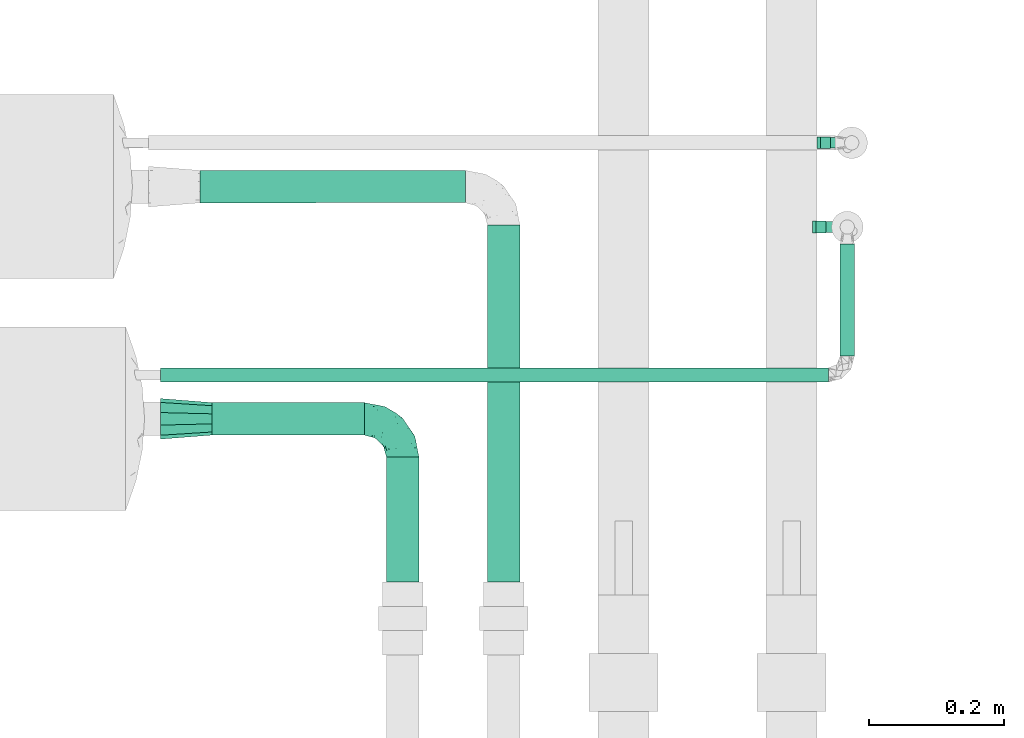
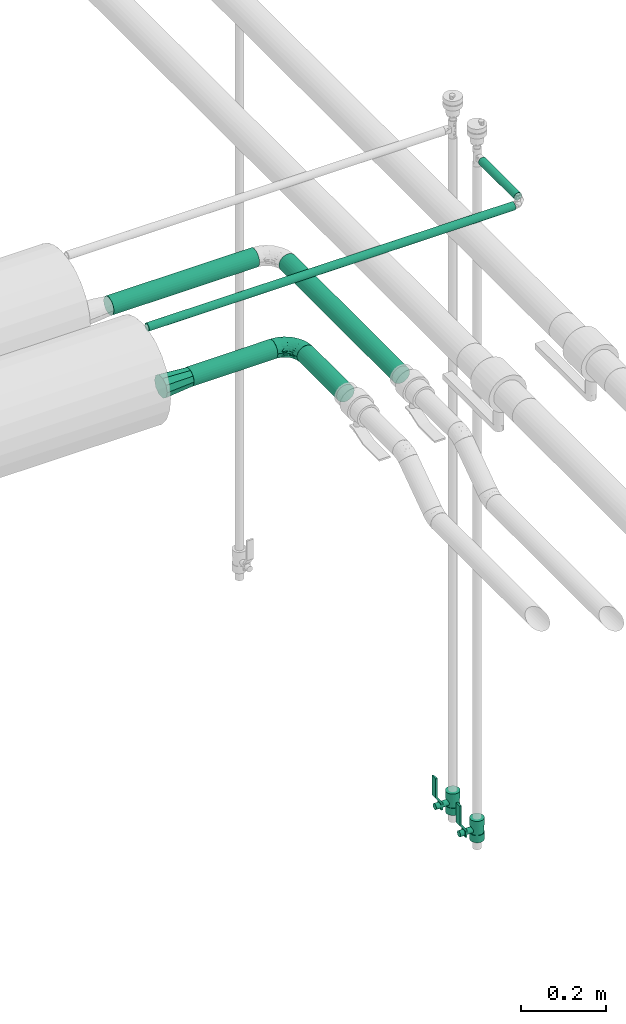
# One storey, part 588 of 827: 6 flow segments, 2 flow controllers, 2 flow fittings.
"""IFC2X3 building model written with IfcOpenShell, lengths in millimetres."""

from ifc_helpers import new_model, entity, si_unit, converted_unit, derived_unit, direction, frame, origin, origin_2d_with_axis, place, context, subcontext, project, spatial, polyline, circle, outline, extrude, faceted_brep, source, transform, mapped, material, material_list, type_object, type_shapes, element, save


model = new_model("IFC2X3")

# Units and contexts
model_context = context("Model", 3, precision=0.01, world=origin(), true_north=direction((6.12303176911189e-17, 1.0)))
body_context = subcontext(model_context, "Body", "Model", "MODEL_VIEW")
ifc_project = project(units=[si_unit("LENGTHUNIT", "METRE", prefix="MILLI"), si_unit("AREAUNIT", "SQUARE_METRE"), si_unit("VOLUMEUNIT", "CUBIC_METRE"), converted_unit("PLANEANGLEUNIT", "DEGREE", entity("IfcRatioMeasure", 0.0174532925199433), si_unit("PLANEANGLEUNIT", "RADIAN"), dimensions=[0, 0, 0, 0, 0, 0, 0]), si_unit("MASSUNIT", "GRAM", prefix="KILO"), derived_unit("MASSDENSITYUNIT", [(si_unit("MASSUNIT", "GRAM", prefix="KILO"), 1), (si_unit("LENGTHUNIT", "METRE"), -3)]), derived_unit("MOMENTOFINERTIAUNIT", [(si_unit("LENGTHUNIT", "METRE"), 4)]), si_unit("TIMEUNIT", "SECOND"), si_unit("FREQUENCYUNIT", "HERTZ"), si_unit("THERMODYNAMICTEMPERATUREUNIT", "DEGREE_CELSIUS"), derived_unit("THERMALTRANSMITTANCEUNIT", [(si_unit("MASSUNIT", "GRAM", prefix="KILO"), 1), (si_unit("THERMODYNAMICTEMPERATUREUNIT", "KELVIN"), -1), (si_unit("TIMEUNIT", "SECOND"), -3)]), derived_unit("VOLUMETRICFLOWRATEUNIT", [(si_unit("LENGTHUNIT", "METRE"), 3), (si_unit("TIMEUNIT", "SECOND"), -1)]), derived_unit("MASSFLOWRATEUNIT", [(si_unit("MASSUNIT", "GRAM", prefix="KILO"), 1), (si_unit("TIMEUNIT", "SECOND"), -1)]), derived_unit("ROTATIONALFREQUENCYUNIT", [(si_unit("TIMEUNIT", "SECOND"), -1)]), si_unit("ELECTRICCURRENTUNIT", "AMPERE"), si_unit("ELECTRICVOLTAGEUNIT", "VOLT"), si_unit("POWERUNIT", "WATT"), si_unit("FORCEUNIT", "NEWTON", prefix="KILO"), si_unit("ILLUMINANCEUNIT", "LUX"), si_unit("LUMINOUSFLUXUNIT", "LUMEN"), si_unit("LUMINOUSINTENSITYUNIT", "CANDELA"), derived_unit("USERDEFINED", [(si_unit("MASSUNIT", "GRAM", prefix="KILO"), -1), (si_unit("LENGTHUNIT", "METRE"), -2), (si_unit("TIMEUNIT", "SECOND"), 3), (si_unit("LUMINOUSFLUXUNIT", "LUMEN"), 1)]), derived_unit("LINEARVELOCITYUNIT", [(si_unit("LENGTHUNIT", "METRE"), 1), (si_unit("TIMEUNIT", "SECOND"), -1)]), si_unit("PRESSUREUNIT", "PASCAL"), derived_unit("USERDEFINED", [(si_unit("LENGTHUNIT", "METRE"), -2), (si_unit("MASSUNIT", "GRAM", prefix="KILO"), 1), (si_unit("TIMEUNIT", "SECOND"), -2)]), derived_unit("LINEARFORCEUNIT", [(si_unit("MASSUNIT", "GRAM", prefix="KILO"), 1), (si_unit("LENGTHUNIT", "METRE"), 1), (si_unit("TIMEUNIT", "SECOND"), -2), (si_unit("LENGTHUNIT", "METRE"), -1)]), derived_unit("PLANARFORCEUNIT", [(si_unit("MASSUNIT", "GRAM", prefix="KILO"), 1), (si_unit("LENGTHUNIT", "METRE"), 1), (si_unit("TIMEUNIT", "SECOND"), -2), (si_unit("LENGTHUNIT", "METRE"), -2)])], contexts=[model_context])

# Site, building, storey
site_placement = place(None, origin())
site = spatial("IfcSite", under=ifc_project, at=site_placement, CompositionType="ELEMENT")
building_placement = place(site_placement, origin())
building = spatial("IfcBuilding", under=site, at=building_placement, CompositionType="ELEMENT")
storey_placement = place(building_placement, frame((0.0, 0.0, 28200.0)))
storey = spatial("IfcBuildingStorey", under=building, at=storey_placement, Name="08", CompositionType="ELEMENT", Elevation=28200.0)

# Flow segments
pipe_segment_type = type_object("IfcPipeSegmentType", PredefinedType="NOTDEFINED")
flow_segment_1_placement = place(storey_placement, frame((25256.69, 14558.36, 3116.0)))
element("IfcFlowSegment", 1, at=flow_segment_1_placement, inside=storey, type_object=pipe_segment_type, context=body_context, shape_type="SweptSolid", body=[
    extrude(circle(Radius=10.65, at=origin_2d_with_axis()), frame((0.0, 12.25, 12.25), z_axis=(1.0, 0.0, 0.0), x_axis=(0.0, 1.0, 0.0)), (0.0, 0.0, 1.0), 991.985477356617),
])
flow_segment_2_placement = place(storey_placement, frame((26264.43, 14598.6, 3116.0)))
element("IfcFlowSegment", 2, at=flow_segment_2_placement, inside=storey, type_object=pipe_segment_type, context=body_context, shape_type="SweptSolid", body=[
    extrude(circle(Radius=10.65, at=origin_2d_with_axis()), frame((12.25, 0.0, 12.25), z_axis=(0.0, 1.0, 0.0), x_axis=(-1.0, 0.0, 0.0)), (0.0, 0.0, 1.0), 166.835366592849),
])
flow_segment_3_placement = place(storey_placement, frame((25314.71, 14824.91, 2974.4)))
element("IfcFlowSegment", 3, at=flow_segment_3_placement, inside=storey, type_object=pipe_segment_type, context=body_context, shape_type="SweptSolid", body=[
    extrude(circle(Radius=24.0, at=origin_2d_with_axis()), frame((0.0, 25.6, 25.6), z_axis=(0.999999985772124, 0.000168688330096528, 0.0), x_axis=(-0.000168688330096528, 0.999999985772124, 0.0)), (0.0, 0.0, 1.0), 394.490392937912),
])
flow_segment_4_placement = place(storey_placement, frame((25332.58, 14479.89, 2973.24)))
element("IfcFlowSegment", 4, at=flow_segment_4_placement, inside=storey, type_object=pipe_segment_type, context=body_context, shape_type="SweptSolid", body=[
    extrude(circle(Radius=24.0, at=origin_2d_with_axis()), frame((0.1, 25.6, 25.6), z_axis=(0.999990523535328, 0.0, 0.00435348590675065), x_axis=(0.0, -1.0, 0.0)), (0.0, 0.0, 1.0), 226.496980574782),
])
flow_segment_5_placement = place(storey_placement, frame((25740.61, 14262.99, 2974.4)))
element("IfcFlowSegment", 5, at=flow_segment_5_placement, inside=storey, type_object=pipe_segment_type, context=body_context, shape_type="SweptSolid", body=[
    extrude(circle(Radius=24.0, at=origin_2d_with_axis()), frame((25.6, 0.0, 25.6), z_axis=(0.0, 1.0, 0.0), x_axis=(-1.0, 0.0, 0.0)), (0.0, 0.0, 1.0), 530.584662846842),
])
flow_segment_6_placement = place(storey_placement, frame((25590.58, 14262.99, 2974.4)))
element("IfcFlowSegment", 6, at=flow_segment_6_placement, inside=storey, type_object=pipe_segment_type, context=body_context, shape_type="SweptSolid", body=[
    extrude(circle(Radius=24.0, at=origin_2d_with_axis()), frame((25.6, 0.0, 25.6), z_axis=(0.0, 1.0, 0.0), x_axis=(-1.0, 0.0, 0.0)), (0.0, 0.0, 1.0), 185.4983901967),
])

# Flow controllers
ifc_material = material()
ifc_material_list = material_list([ifc_material, ifc_material, ifc_material, ifc_material, ifc_material])
valve_type = type_object("IfcValveType", PredefinedType="NOTDEFINED", material=ifc_material_list)
shared_shape_1 = source(origin(), body_context, "Body", "SweptSolid", [
    extrude(circle(Radius=17.5, at=origin_2d_with_axis()), frame((-30.5, 0.0, 0.0), z_axis=(1.0, 0.0, 0.0), x_axis=(0.0, 1.0, 0.0)), (0.0, 0.0, 1.0), 20.3333333333333),
    extrude(circle(Radius=16.0, at=origin_2d_with_axis()), frame((-10.17, 0.0, 0.0), z_axis=(1.0, 0.0, 0.0), x_axis=(0.0, 1.0, 0.0)), (0.0, 0.0, 1.0), 20.3333333333333),
    extrude(circle(Radius=17.5, at=origin_2d_with_axis()), frame((10.17, 0.0, 0.0), z_axis=(1.0, 0.0, 0.0), x_axis=(0.0, 1.0, 0.0)), (0.0, 0.0, 1.0), 20.3333333333333),
    extrude(outline(polyline([(-38.75, -5.0), (-38.75, -10.0), (-17.92, -10.0), (2.08, 5.0), (56.25, 5.0), (56.25, 10.0), (0.42, 10.0), (-19.58, -5.0), (-38.75, -5.0)])), frame((28.75, -8.75, 41.5), z_axis=(0.0, -1.0, 0.0), x_axis=(1.0, 0.0, 0.0)), (0.0, 0.0, -1.0), 17.5),
    extrude(circle(Radius=8.0, at=origin_2d_with_axis()), origin(), (0.0, 0.0, 1.0), 49.0),
])
type_shapes(valve_type, [shared_shape_1])
for number, where, z_axis, x_axis in (
    (7, (26283.3, 14915.6, 1205.0), (-1.0, 0.0, 0.0), (0.0, 0.0, 1.0)),
    (8, (26276.67, 14790.44, 1205.0), (-1.0, 0.0, 0.0), (0.0, 0.0, 1.0)),
):
    element("IfcFlowController", number, at=place(storey_placement, frame(where, z_axis=z_axis, x_axis=x_axis)), inside=storey, type_object=valve_type, material=ifc_material, context=body_context, shape_type="MappedRepresentation", body=[
        mapped(shared_shape_1, transform((0.0, 0.0, 0.0), scale=1.0)),
    ])

# Flow fittings
pipe_fitting_type_1 = type_object("IfcPipeFittingType", Name="ADSK_1", PredefinedType="NOTDEFINED", material=ifc_material)
shared_shape_2 = source(origin(), body_context, "Body", "Brep", [
    faceted_brep([(-57.0, 12.07, -20.91), (-57.0, 6.25, -23.33), (-57.0, 0.0, -24.15), (-57.0, -6.25, -23.33), (-57.0, -12.08, -20.91), (-57.0, -17.08, -17.08), (-57.0, -20.91, -12.08), (-57.0, -23.33, -6.25), (-57.0, -24.15, 0.0), (-57.0, -23.33, 6.25), (-57.0, -20.91, 12.07), (-57.0, -17.08, 17.08), (-57.0, -12.08, 20.91), (-57.0, -6.25, 23.33), (-57.0, 0.0, 24.15), (-57.0, 6.25, 23.33), (-57.0, 12.07, 20.91), (-57.0, 17.08, 17.08), (-57.0, 20.91, 12.07), (-57.0, 23.33, 6.25), (-57.0, 24.15, 0.0), (-57.0, 23.33, -6.25), (-57.0, 20.91, -12.08), (-57.0, 17.08, -17.08), (0.0, 57.0, -24.15), (-6.25, 57.0, -23.33), (-12.07, 57.0, -20.91), (-17.08, 57.0, -17.08), (-20.91, 57.0, -12.08), (-23.33, 57.0, -6.25), (-24.15, 57.0, 0.0), (-23.33, 57.0, 6.25), (-20.91, 57.0, 12.07), (-17.08, 57.0, 17.08), (-12.07, 57.0, 20.91), (-6.25, 57.0, 23.33), (0.0, 57.0, 24.15), (6.25, 57.0, 23.33), (12.08, 57.0, 20.91), (17.08, 57.0, 17.08), (20.91, 57.0, 12.07), (23.33, 57.0, 6.25), (24.15, 57.0, 0.0), (23.33, 57.0, -6.25), (20.91, 57.0, -12.08), (17.08, 57.0, -17.08), (12.08, 57.0, -20.91), (6.25, 57.0, -23.33), (14.9, 21.14, 6.17), (13.61, 24.64, 12.48), (6.23, 8.95, 8.98), (-41.47, -21.06, 0.0), (-41.92, -18.38, 13.72), (-24.64, -13.61, 12.48), (-37.37, -13.24, 18.15), (-6.8, -4.93, 8.18), (-21.76, -15.19, 6.22), (-12.78, -9.18, 0.0), (-37.73, -20.51, 7.75), (-7.38, 7.38, 20.24), (-23.37, -4.26, 20.42), (-11.9, -3.19, 15.86), (-42.14, -8.7, 21.82), (13.24, 37.37, 18.15), (9.33, 23.53, 16.85), (4.26, 23.37, 20.42), (2.77, 10.92, 15.55), (-29.46, 0.91, 23.52), (-44.13, 20.56, 15.69), (-39.25, 26.33, 10.88), (-49.02, 22.92, 9.96), (-34.58, 23.87, 17.15), (-15.8, 6.8, 22.81), (-8.67, 20.47, 23.88), (-18.12, 12.9, 24.08), (-48.29, 14.92, 19.65), (-44.06, -2.85, 23.78), (-9.23, 48.95, 22.58), (-3.78, 42.74, 24.07), (-40.34, 4.26, 24.09), (-44.02, 26.14, 5.46), (-44.04, 9.88, 22.74), (-4.95, 16.87, 22.52), (-2.75, 1.43, 12.5), (-25.48, 40.98, 10.71), (20.51, 37.73, 7.75), (18.38, 41.92, 13.72), (8.7, 42.14, 21.82), (-25.95, -17.97, 0.0), (2.85, 44.06, 23.78), (21.06, 41.47, 0.0), (17.97, 25.95, 0.0), (-24.04, -9.27, 17.13), (-33.26, 33.26, 5.86), (-28.55, 40.57, 0.0), (-40.57, 28.55, 0.0), (-25.29, 47.19, 4.06), (-27.01, 31.1, 16.77), (-15.7, 43.95, 19.9), (-20.27, 45.22, 15.61), (-30.53, 31.98, 12.64), (-11.28, 38.33, 22.92), (-9.97, 27.88, 24.09), (-20.15, 30.26, 21.25), (-31.25, 11.75, 23.64), (-28.75, 7.23, 24.15), (-29.53, 18.06, 22.27), (-28.44, 24.21, 20.02), (-37.55, 17.7, 20.26), (-15.88, 29.25, 22.99), (-20.82, 20.82, 23.44), (-0.91, 29.46, 23.52), (-13.5, -7.67, 12.04), (1.49, 1.56, 5.16), (8.86, 10.35, 4.59), (0.38, -0.38, 0.0), (9.18, 12.78, 0.0), (-37.37, -13.24, -18.15), (8.86, 10.35, -4.59), (-45.22, 20.27, -15.61), (-43.95, 15.7, -19.9), (-38.33, 11.28, -22.92), (-48.95, 9.23, -22.58), (-47.19, 25.29, -4.06), (-33.26, 33.26, -5.86), (18.38, 41.92, -13.72), (-30.26, 20.15, -21.25), (2.85, 44.06, -23.78), (-4.26, 40.34, -24.09), (-40.98, 25.48, -10.71), (-41.92, -18.38, -13.72), (9.25, 23.5, -16.92), (4.26, 23.37, -20.42), (13.24, 37.37, -18.15), (-37.73, -20.51, -7.75), (-11.75, 31.25, -23.64), (-7.23, 28.75, -24.15), (-12.9, 18.12, -24.08), (8.7, 42.14, -21.82), (-44.06, -2.85, -23.78), (-6.8, 15.8, -22.81), (-20.47, 8.67, -23.88), (-24.64, -13.61, -12.48), (-42.74, 3.78, -24.07), (-18.06, 29.53, -22.27), (-24.21, 28.44, -20.02), (-27.88, 9.97, -24.09), (-31.1, 27.01, -16.77), (-26.14, 44.02, -5.46), (14.9, 21.14, -6.17), (20.51, 37.73, -7.75), (-9.88, 44.04, -22.74), (-20.56, 44.13, -15.69), (-21.76, -15.19, -6.22), (-13.5, -7.67, -12.04), (-24.14, -9.76, -16.74), (-11.9, -3.19, -15.86), (-14.92, 48.29, -19.65), (-23.37, -4.26, -20.42), (-0.91, 29.46, -23.52), (-26.33, 39.25, -10.88), (-23.87, 34.58, -17.15), (-42.14, -8.7, -21.82), (-22.92, 49.02, -9.96), (13.61, 24.64, -12.48), (-31.98, 30.53, -12.64), (-16.87, 4.95, -22.52), (-17.7, 37.55, -20.26), (-29.25, 15.88, -22.99), (-20.82, 20.82, -23.44), (-29.46, 0.91, -23.52), (-7.38, 7.38, -20.24), (2.77, 10.92, -15.55), (6.23, 8.95, -8.98), (-6.8, -4.93, -8.18), (-2.81, 1.41, -12.54), (1.49, 1.56, -5.16)], [[[0, 1, 2, 3, 4, 5, 6, 7, 8, 9, 10, 11, 12, 13, 14, 15, 16, 17, 18, 19, 20, 21, 22, 23]], [[24, 25, 26, 27, 28, 29, 30, 31, 32, 33, 34, 35, 36, 37, 38, 39, 40, 41, 42, 43, 44, 45, 46, 47]], [[48, 49, 50]], [[9, 8, 51]], [[52, 53, 54]], [[55, 56, 57]], [[10, 58, 52]], [[9, 58, 10]], [[59, 60, 61]], [[54, 12, 11]], [[54, 62, 12]], [[63, 39, 38]], [[64, 65, 66]], [[62, 60, 67]], [[68, 69, 70]], [[71, 69, 68]], [[72, 73, 74]], [[16, 75, 17]], [[13, 76, 14]], [[35, 77, 78]], [[14, 79, 15]], [[17, 68, 18]], [[14, 76, 79]], [[20, 19, 80]], [[70, 19, 18]], [[81, 15, 79]], [[15, 81, 16]], [[73, 72, 82]], [[66, 83, 50]], [[32, 31, 84]], [[85, 86, 49]], [[63, 87, 65]], [[56, 58, 88]], [[36, 89, 37]], [[85, 41, 40]], [[36, 35, 78]], [[90, 41, 85]], [[40, 39, 86]], [[12, 62, 13]], [[86, 85, 40]], [[48, 85, 49]], [[85, 91, 90]], [[87, 38, 37]], [[92, 60, 54]], [[80, 69, 93]], [[93, 94, 95]], [[10, 52, 11]], [[94, 96, 30]], [[97, 98, 99]], [[80, 93, 95]], [[100, 97, 84]], [[99, 98, 33]], [[101, 102, 78]], [[103, 101, 98]], [[96, 31, 30]], [[77, 98, 101]], [[77, 35, 34]], [[34, 33, 98]], [[9, 51, 58]], [[87, 63, 38]], [[104, 105, 74]], [[106, 103, 107]], [[106, 81, 104]], [[75, 68, 17]], [[108, 107, 71]], [[33, 32, 99]], [[109, 103, 110]], [[101, 109, 102]], [[89, 78, 111]], [[53, 52, 58]], [[54, 11, 52]], [[60, 62, 54]], [[88, 58, 51]], [[76, 62, 67]], [[53, 112, 92]], [[60, 59, 72]], [[39, 63, 86]], [[49, 86, 63]], [[89, 87, 37]], [[42, 41, 90]], [[111, 82, 65]], [[111, 65, 87]], [[65, 59, 66]], [[104, 81, 79]], [[75, 81, 108]], [[32, 84, 99]], [[97, 99, 84]], [[98, 97, 103]], [[106, 107, 108]], [[74, 102, 110]], [[111, 78, 102]], [[74, 110, 104]], [[74, 67, 72]], [[61, 92, 112]], [[66, 59, 61]], [[56, 53, 58]], [[66, 50, 49]], [[61, 112, 83]], [[66, 49, 64]], [[78, 89, 36]], [[87, 89, 111]], [[62, 76, 13]], [[79, 76, 67]], [[100, 93, 69]], [[96, 93, 84]], [[55, 113, 50]], [[113, 114, 50]], [[104, 79, 105]], [[106, 104, 110]], [[20, 80, 95]], [[85, 48, 91]], [[115, 114, 113]], [[116, 91, 48]], [[70, 80, 19]], [[93, 96, 94]], [[84, 31, 96]], [[103, 106, 110]], [[81, 106, 108]], [[103, 97, 107]], [[71, 107, 97]], [[71, 97, 100]], [[108, 71, 68]], [[79, 67, 105]], [[67, 74, 105]], [[115, 113, 57]], [[112, 56, 55]], [[56, 88, 57]], [[60, 72, 67]], [[82, 72, 59]], [[65, 82, 59]], [[82, 111, 73]], [[111, 102, 73]], [[102, 74, 73]], [[81, 75, 16]], [[68, 75, 108]], [[68, 70, 18]], [[80, 70, 69]], [[98, 77, 34]], [[78, 77, 101]], [[93, 100, 84]], [[71, 100, 69]], [[102, 109, 110]], [[101, 103, 109]], [[53, 92, 54]], [[61, 60, 92]], [[56, 112, 53]], [[83, 112, 55]], [[50, 83, 55]], [[61, 83, 66]], [[49, 63, 64]], [[65, 64, 63]], [[57, 113, 55]], [[114, 115, 116]], [[116, 48, 114]], [[48, 50, 114]], [[117, 5, 4]], [[116, 115, 118]], [[119, 120, 23]], [[121, 122, 120]], [[95, 123, 20]], [[0, 23, 120]], [[124, 95, 94]], [[125, 45, 44]], [[121, 120, 126]], [[24, 127, 128]], [[22, 21, 129]], [[0, 122, 1]], [[5, 117, 130]], [[131, 132, 133]], [[134, 88, 51]], [[135, 136, 137]], [[6, 5, 130]], [[46, 138, 47]], [[139, 3, 2]], [[140, 141, 137]], [[6, 134, 7]], [[134, 130, 142]], [[143, 2, 1]], [[144, 126, 145]], [[121, 146, 143]], [[147, 120, 119]], [[94, 148, 124]], [[149, 150, 91]], [[30, 29, 148]], [[151, 25, 128]], [[27, 152, 28]], [[134, 153, 88]], [[154, 155, 156]], [[27, 26, 157]], [[151, 26, 25]], [[155, 158, 156]], [[24, 47, 127]], [[1, 122, 143]], [[138, 132, 159]], [[160, 152, 161]], [[24, 128, 25]], [[46, 133, 138]], [[162, 117, 4]], [[148, 160, 124]], [[152, 160, 163]], [[154, 142, 155]], [[45, 125, 133]], [[133, 46, 45]], [[125, 164, 133]], [[51, 7, 134]], [[42, 90, 43]], [[165, 147, 129]], [[153, 134, 142]], [[43, 150, 44]], [[162, 4, 3]], [[141, 140, 166]], [[117, 162, 158]], [[163, 29, 28]], [[43, 90, 150]], [[123, 21, 20]], [[144, 151, 135]], [[157, 152, 27]], [[167, 145, 161]], [[23, 22, 119]], [[168, 126, 169]], [[121, 168, 146]], [[139, 143, 170]], [[142, 130, 117]], [[8, 7, 51]], [[134, 6, 130]], [[139, 162, 3]], [[170, 166, 158]], [[170, 158, 162]], [[158, 171, 156]], [[44, 150, 125]], [[91, 150, 90]], [[164, 125, 150]], [[132, 138, 133]], [[127, 138, 159]], [[131, 164, 172]], [[132, 171, 140]], [[135, 151, 128]], [[157, 151, 167]], [[22, 129, 119]], [[147, 119, 129]], [[120, 147, 126]], [[144, 145, 167]], [[137, 146, 169]], [[170, 143, 146]], [[137, 169, 135]], [[137, 159, 140]], [[171, 172, 156]], [[173, 174, 175]], [[156, 175, 154]], [[174, 57, 153]], [[132, 172, 171]], [[172, 164, 173]], [[143, 139, 2]], [[162, 139, 170]], [[138, 127, 47]], [[128, 127, 159]], [[165, 124, 160]], [[123, 124, 129]], [[149, 173, 164]], [[176, 174, 173]], [[135, 128, 136]], [[144, 135, 169]], [[150, 149, 164]], [[176, 118, 115]], [[149, 91, 116]], [[30, 148, 94]], [[163, 148, 29]], [[124, 123, 95]], [[129, 21, 123]], [[126, 144, 169]], [[151, 144, 167]], [[126, 147, 145]], [[161, 145, 147]], [[161, 147, 165]], [[167, 161, 152]], [[128, 159, 136]], [[159, 137, 136]], [[154, 153, 142]], [[132, 140, 159]], [[174, 176, 57]], [[57, 88, 153]], [[166, 140, 171]], [[158, 166, 171]], [[166, 170, 141]], [[170, 146, 141]], [[146, 137, 141]], [[151, 157, 26]], [[152, 157, 167]], [[152, 163, 28]], [[148, 163, 160]], [[120, 122, 0]], [[143, 122, 121]], [[124, 165, 129]], [[161, 165, 160]], [[146, 168, 169]], [[121, 126, 168]], [[142, 117, 155]], [[158, 155, 117]], [[175, 156, 172]], [[153, 154, 174]], [[173, 175, 172]], [[174, 154, 175]], [[164, 131, 133]], [[172, 132, 131]], [[176, 173, 118]], [[57, 176, 115]], [[173, 149, 118]], [[149, 116, 118]]]),
])
type_shapes(pipe_fitting_type_1, [shared_shape_2])
flow_fitting_1_placement = place(storey_placement, frame((25616.18, 14505.49, 3000.0), z_axis=(-0.00320586404388479, 0.0, 0.999994861204663), x_axis=(0.0, 1.0, 0.0)))
element("IfcFlowFitting", 9, at=flow_fitting_1_placement, inside=storey, type_object=pipe_fitting_type_1, material=ifc_material, Name="ADSK_1", ObjectType="ADSK_1", context=body_context, shape_type="MappedRepresentation", body=[
    mapped(shared_shape_2, transform((0.0, 0.0, 0.0), scale=1.0)),
])
pipe_fitting_type_2 = type_object("IfcPipeFittingType", Name="ADSK_1", PredefinedType="NOTDEFINED", material=ifc_material)
shared_shape_3 = source(origin(), body_context, "Body", "Brep", [
    faceted_brep([(76.0, -30.15, 0.0), (76.0, -28.24, -5.87), (76.0, -26.33, -11.75), (76.0, -24.39, -17.72), (76.0, -16.85, -23.2), (76.0, -9.32, -28.67), (76.0, 0.0, -28.67), (76.0, 9.32, -28.67), (76.0, 16.85, -23.2), (76.0, 24.39, -17.72), (76.0, 26.33, -11.75), (76.0, 28.24, -5.87), (76.0, 30.15, 0.0), (76.0, 28.24, 5.87), (76.0, 26.33, 11.75), (76.0, 24.39, 17.72), (76.0, 16.85, 23.2), (76.0, 9.32, 28.67), (76.0, 0.0, 28.67), (76.0, -9.32, 28.67), (76.0, -16.85, 23.2), (76.0, -24.39, 17.72), (76.0, -26.33, 11.75), (76.0, -28.24, 5.87), (0.0, -19.54, -14.2), (0.0, -21.84, -7.1), (0.0, -24.15, 0.0), (0.0, -21.84, 7.1), (0.0, -19.54, 14.2), (0.0, -13.5, 18.58), (0.0, -7.46, 22.97), (0.0, 0.0, 22.97), (0.0, 7.46, 22.97), (0.0, 13.5, 18.58), (0.0, 19.54, 14.2), (0.0, 21.84, 7.1), (0.0, 24.15, 0.0), (0.0, 21.84, -7.1), (0.0, 19.54, -14.2), (0.0, 13.5, -18.58), (0.0, 7.46, -22.97), (0.0, 0.0, -22.97), (0.0, -7.46, -22.97), (0.0, -13.5, -18.58)], [[[0, 1, 2, 3, 4, 5, 6, 7, 8, 9, 10, 11, 12, 13, 14, 15, 16, 17, 18, 19, 20, 21, 22, 23]], [[24, 25, 26, 27, 28, 29, 30, 31, 32, 33, 34, 35, 36, 37, 38, 39, 40, 41, 42, 43]], [[24, 3, 2, 1, 0, 26, 25]], [[7, 40, 39, 38, 9, 8]], [[42, 5, 4, 3, 24, 43]], [[6, 5, 42, 41, 40, 7]], [[11, 10, 9, 38, 37, 36, 12]], [[34, 15, 14, 13, 12, 36, 35]], [[19, 30, 29, 28, 21, 20]], [[32, 17, 16, 15, 34, 33]], [[18, 17, 32, 31, 30, 19]], [[23, 22, 21, 28, 27, 26, 0]]]),
])
type_shapes(pipe_fitting_type_2, [shared_shape_3])
flow_fitting_2_placement = place(storey_placement, frame((25332.68, 14505.49, 2998.83), z_axis=(-0.00776606518238528, 0.0, 0.999969843661089), x_axis=(-0.999969843661089, 0.0, -0.00776606518238528)))
element("IfcFlowFitting", 10, at=flow_fitting_2_placement, inside=storey, type_object=pipe_fitting_type_2, material=ifc_material, Name="ADSK_1", ObjectType="ADSK_1", context=body_context, shape_type="MappedRepresentation", body=[
    mapped(shared_shape_3, transform((0.0, 0.0, 0.0), scale=1.0)),
])

save(model, "model.ifc")
